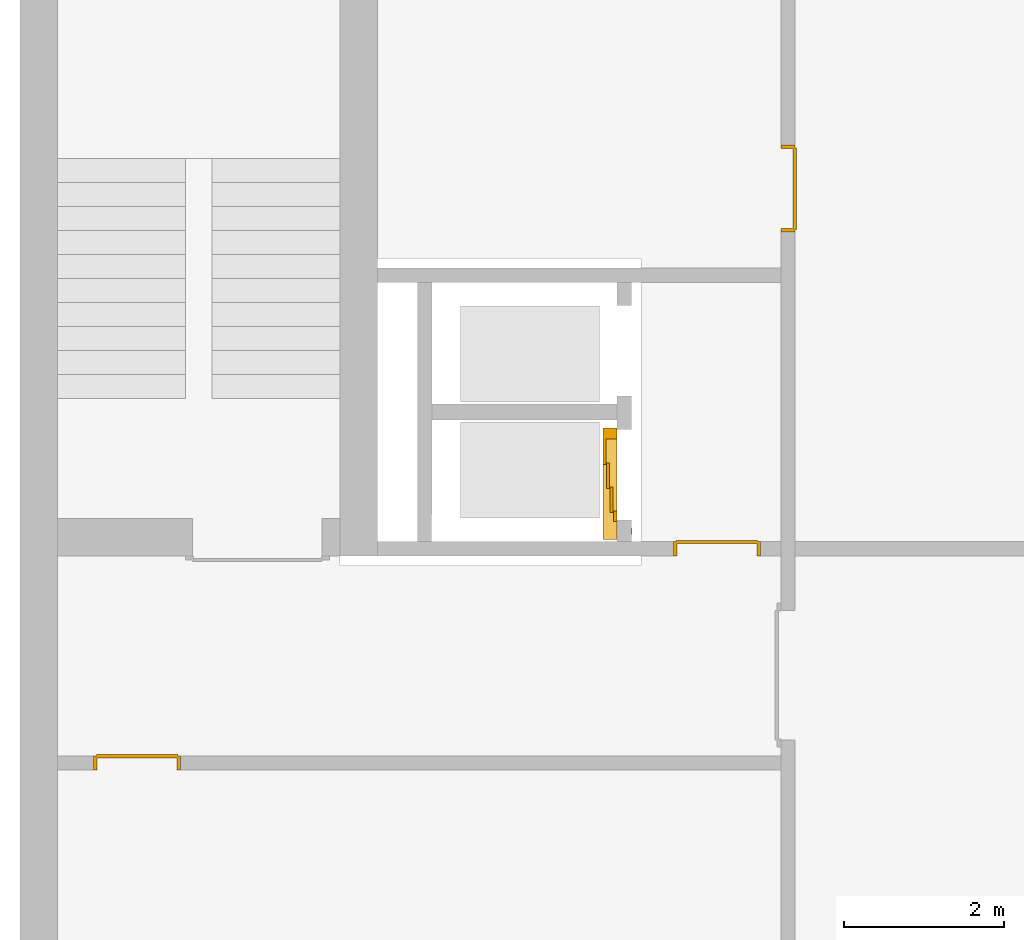
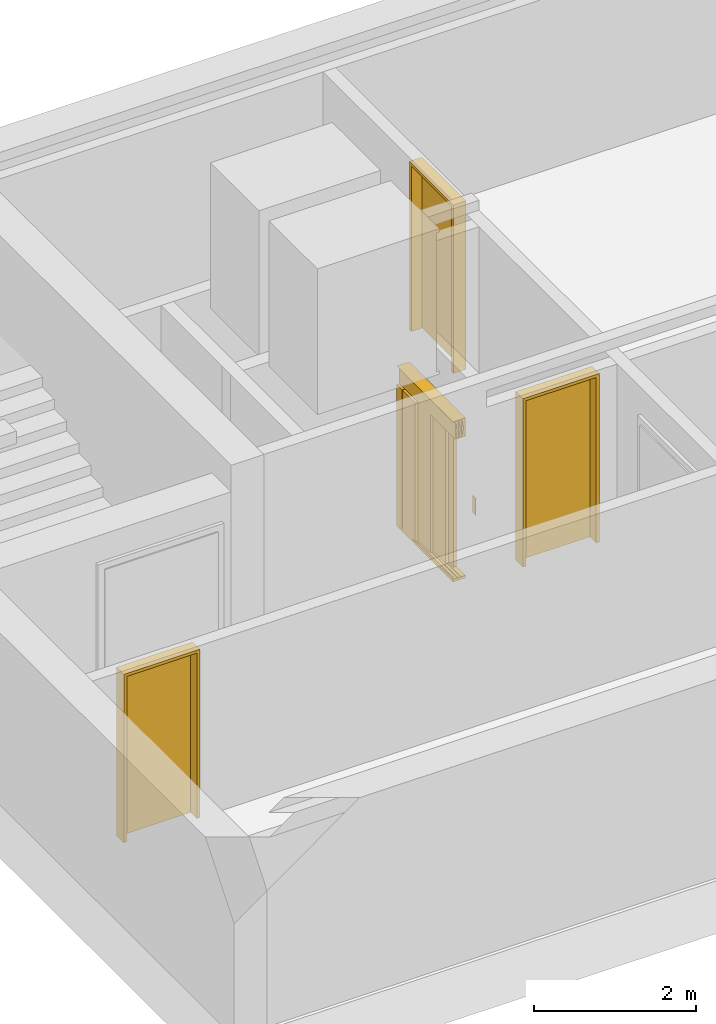
# One storey, part 4 of 5: 4 doors.
"""IFC4 building model written with IfcOpenShell, lengths in metres."""

from ifc_helpers import new_model, entity, si_unit, converted_unit, derived_unit, direction, frame, origin_with_axes, place, context, subcontext, project, spatial, polygons, source, transform, mapped, type_object, element, save


model = new_model("IFC4")

# Units and contexts
model_context = context("Model", 3, precision=1e-05, world=origin_with_axes(), true_north=direction((0.0, 1.0)))
body_context = subcontext(model_context, "Body", "Model", "MODEL_VIEW")
ifc_project = project(units=[si_unit("LENGTHUNIT", "METRE"), si_unit("AREAUNIT", "SQUARE_METRE"), si_unit("VOLUMEUNIT", "CUBIC_METRE"), converted_unit("PLANEANGLEUNIT", "DEGREE", entity("IfcPlaneAngleMeasure", 0.0174532925199433), si_unit("PLANEANGLEUNIT", "RADIAN"), dimensions=[0, 0, 0, 0, 0, 0, 0]), converted_unit("TIMEUNIT", "Year", entity("IfcTimeMeasure", 31557600.0), si_unit("TIMEUNIT", "SECOND"), dimensions=[0, 0, 1, 0, 0, 0, 0]), si_unit("MASSUNIT", "GRAM", prefix="KILO"), si_unit("THERMODYNAMICTEMPERATUREUNIT", "DEGREE_CELSIUS"), si_unit("LUMINOUSINTENSITYUNIT", "LUMEN"), si_unit("ENERGYUNIT", "JOULE", prefix="MEGA"), derived_unit("THERMALCONDUCTANCEUNIT", [(si_unit("POWERUNIT", "WATT"), 1), (si_unit("LENGTHUNIT", "METRE"), -1), (si_unit("THERMODYNAMICTEMPERATUREUNIT", "KELVIN"), -1)]), derived_unit("SPECIFICHEATCAPACITYUNIT", [(si_unit("ENERGYUNIT", "JOULE"), 1), (si_unit("MASSUNIT", "GRAM", prefix="KILO"), -1), (si_unit("THERMODYNAMICTEMPERATUREUNIT", "KELVIN"), -1)]), derived_unit("MASSDENSITYUNIT", [(si_unit("MASSUNIT", "GRAM", prefix="KILO"), 1), (si_unit("VOLUMEUNIT", "CUBIC_METRE"), -1)])], contexts=[model_context])

# Site, building, storey
site_placement = place(None, origin_with_axes())
site = spatial("IfcSite", under=ifc_project, at=site_placement, CompositionType="ELEMENT")
building_placement = place(None, origin_with_axes())
building = spatial("IfcBuilding", under=site, at=building_placement, CompositionType="ELEMENT")
storey_placement = place(None, frame((0.0, 0.0, -3.0), z_axis=(0.0, 0.0, 1.0), x_axis=(1.0, 0.0, 0.0)))
storey = spatial("IfcBuildingStorey", under=building, at=storey_placement, Name="UG", CompositionType="ELEMENT", Elevation=-3.0)

# Doors
door_type_1 = type_object("IfcDoorType", Name="27", OperationType="DOUBLE_DOOR_SLIDING", PredefinedType="DOOR")
shared_shape = source(origin_with_axes(), body_context, "Body", "Tessellation", [
    polygons([(-0.808333333333334, 0.135, 2.1), (-0.808333333333334, 0.135, 2.138), (0.585, 0.135, 2.138), (0.585, 0.135, 2.1), (-0.808333333333334, 0.0, 2.1), (-0.808333333333334, 0.0, 2.38), (-0.808333333333334, 0.18, 2.38), (-0.808333333333334, 0.18, 2.377), (-0.808333333333334, 0.003, 2.377), (-0.808333333333334, 0.003, 2.103), (-0.808333333333334, 0.132, 2.103), (-0.808333333333334, 0.132, 2.138), (0.585, 0.132, 2.138), (0.585, 0.132, 2.103), (0.585, 0.00299999999999992, 2.103), (0.585, 0.00299999999999992, 2.377), (0.585, 0.18, 2.377), (0.585, 0.18, 2.38), (0.585, 0.0, 2.38), (0.585, 0.0, 2.1)], [[[1, 2, 3, 4]], [[1, 5, 6, 7, 8, 9, 10, 11, 12, 2]], [[2, 12, 13, 3]], [[4, 3, 13, 14, 15, 16, 17, 18, 19, 20]], [[5, 1, 4, 20]], [[6, 5, 20, 19]], [[7, 6, 19, 18]], [[8, 7, 18, 17]], [[9, 8, 17, 16]], [[10, 9, 16, 15]], [[11, 10, 15, 14]], [[12, 11, 14, 13]]], closed=True),
    polygons([(-0.808333333333334, 0.05, 2.103), (-0.808333333333334, 0.055, 2.103), (0.585, 0.0549999999999999, 2.103), (0.585, 0.0499999999999999, 2.103), (-0.808333333333334, 0.05, 2.34), (-0.808333333333334, 0.055, 2.34), (0.585, 0.0549999999999999, 2.34), (0.585, 0.0499999999999999, 2.34)], [[[1, 2, 3, 4]], [[1, 5, 6, 2]], [[2, 6, 7, 3]], [[4, 3, 7, 8]], [[5, 1, 4, 8]], [[6, 5, 8, 7]]], closed=True),
    polygons([(-0.808333333333334, 0.05, 2.33), (-0.808333333333334, 0.04, 2.33), (0.585, 0.0399999999999999, 2.33), (0.585, 0.0499999999999999, 2.33), (-0.808333333333334, 0.05, 2.27), (-0.808333333333334, 0.04, 2.27), (0.585, 0.0399999999999999, 2.27), (0.585, 0.0499999999999999, 2.27)], [[[1, 2, 3, 4]], [[1, 5, 6, 2]], [[2, 6, 7, 3]], [[4, 3, 7, 8]], [[5, 1, 4, 8]], [[6, 5, 8, 7]]], closed=True),
    polygons([(-0.808333333333334, 0.05, 2.2), (-0.808333333333334, 0.04, 2.2), (0.585, 0.0399999999999999, 2.2), (0.585, 0.0499999999999999, 2.2), (-0.808333333333334, 0.05, 2.16), (-0.808333333333334, 0.04, 2.16), (0.585, 0.0399999999999999, 2.16), (0.585, 0.0499999999999999, 2.16)], [[[1, 2, 3, 4]], [[1, 5, 6, 2]], [[2, 6, 7, 3]], [[4, 3, 7, 8]], [[5, 1, 4, 8]], [[6, 5, 8, 7]]], closed=True),
    polygons([(-0.808333333333334, 0.05, 2.27), (-0.808333333333334, 0.03, 2.27), (0.585, 0.0299999999999999, 2.27), (0.585, 0.0499999999999999, 2.27), (-0.808333333333334, 0.05, 2.2), (-0.808333333333334, 0.03, 2.2), (0.585, 0.0299999999999999, 2.2), (0.585, 0.0499999999999999, 2.2)], [[[1, 2, 3, 4]], [[1, 5, 6, 2]], [[2, 6, 7, 3]], [[4, 3, 7, 8]], [[5, 1, 4, 8]], [[6, 5, 8, 7]]], closed=True),
    polygons([(-0.808333333333334, 0.095, 2.103), (-0.808333333333334, 0.1, 2.103), (0.585, 0.0999999999999999, 2.103), (0.585, 0.0949999999999999, 2.103), (-0.808333333333334, 0.095, 2.34), (-0.808333333333334, 0.1, 2.34), (0.585, 0.0999999999999999, 2.34), (0.585, 0.0949999999999999, 2.34)], [[[1, 2, 3, 4]], [[1, 5, 6, 2]], [[2, 6, 7, 3]], [[4, 3, 7, 8]], [[5, 1, 4, 8]], [[6, 5, 8, 7]]], closed=True),
    polygons([(-0.808333333333334, 0.095, 2.33), (-0.808333333333334, 0.085, 2.33), (0.585, 0.0849999999999999, 2.33), (0.585, 0.0949999999999999, 2.33), (-0.808333333333334, 0.095, 2.27), (-0.808333333333334, 0.085, 2.27), (0.585, 0.0849999999999999, 2.27), (0.585, 0.0949999999999999, 2.27)], [[[1, 2, 3, 4]], [[1, 5, 6, 2]], [[2, 6, 7, 3]], [[4, 3, 7, 8]], [[5, 1, 4, 8]], [[6, 5, 8, 7]]], closed=True),
    polygons([(-0.808333333333334, 0.095, 2.2), (-0.808333333333334, 0.085, 2.2), (0.585, 0.0849999999999999, 2.2), (0.585, 0.0949999999999999, 2.2), (-0.808333333333334, 0.095, 2.16), (-0.808333333333334, 0.085, 2.16), (0.585, 0.0849999999999999, 2.16), (0.585, 0.0949999999999999, 2.16)], [[[1, 2, 3, 4]], [[1, 5, 6, 2]], [[2, 6, 7, 3]], [[4, 3, 7, 8]], [[5, 1, 4, 8]], [[6, 5, 8, 7]]], closed=True),
    polygons([(-0.808333333333334, 0.095, 2.27), (-0.808333333333334, 0.075, 2.27), (0.585, 0.0749999999999999, 2.27), (0.585, 0.0949999999999999, 2.27), (-0.808333333333334, 0.095, 2.2), (-0.808333333333334, 0.075, 2.2), (0.585, 0.0749999999999999, 2.2), (0.585, 0.0949999999999999, 2.2)], [[[1, 2, 3, 4]], [[1, 5, 6, 2]], [[2, 6, 7, 3]], [[4, 3, 7, 8]], [[5, 1, 4, 8]], [[6, 5, 8, 7]]], closed=True),
    polygons([(-0.808333333333334, 0.14, 2.103), (-0.808333333333334, 0.145, 2.103), (0.585, 0.145, 2.103), (0.585, 0.14, 2.103), (-0.808333333333334, 0.14, 2.34), (-0.808333333333334, 0.145, 2.34), (0.585, 0.145, 2.34), (0.585, 0.14, 2.34)], [[[1, 2, 3, 4]], [[1, 5, 6, 2]], [[2, 6, 7, 3]], [[4, 3, 7, 8]], [[5, 1, 4, 8]], [[6, 5, 8, 7]]], closed=True),
    polygons([(-0.808333333333334, 0.14, 2.33), (-0.808333333333334, 0.13, 2.33), (0.585, 0.13, 2.33), (0.585, 0.14, 2.33), (-0.808333333333334, 0.14, 2.27), (-0.808333333333334, 0.13, 2.27), (0.585, 0.13, 2.27), (0.585, 0.14, 2.27)], [[[1, 2, 3, 4]], [[1, 5, 6, 2]], [[2, 6, 7, 3]], [[4, 3, 7, 8]], [[5, 1, 4, 8]], [[6, 5, 8, 7]]], closed=True),
    polygons([(-0.808333333333334, 0.14, 2.2), (-0.808333333333334, 0.13, 2.2), (0.585, 0.13, 2.2), (0.585, 0.14, 2.2), (-0.808333333333334, 0.14, 2.16), (-0.808333333333334, 0.13, 2.16), (0.585, 0.13, 2.16), (0.585, 0.14, 2.16)], [[[1, 2, 3, 4]], [[1, 5, 6, 2]], [[2, 6, 7, 3]], [[4, 3, 7, 8]], [[5, 1, 4, 8]], [[6, 5, 8, 7]]], closed=True),
    polygons([(-0.808333333333334, 0.14, 2.27), (-0.808333333333334, 0.12, 2.27), (0.585, 0.12, 2.27), (0.585, 0.14, 2.27), (-0.808333333333334, 0.14, 2.2), (-0.808333333333334, 0.12, 2.2), (0.585, 0.12, 2.2), (0.585, 0.14, 2.2)], [[[1, 2, 3, 4]], [[1, 5, 6, 2]], [[2, 6, 7, 3]], [[4, 3, 7, 8]], [[5, 1, 4, 8]], [[6, 5, 8, 7]]], closed=True),
    polygons([(-0.808333333333334, 0.0, 0.0), (-0.808333333333334, 0.0, -0.04), (0.585, 0.0, -0.04), (0.585, 0.0, 0.0), (-0.808333333333334, 0.065, 0.0), (-0.808333333333334, 0.065, -0.01), (-0.808333333333334, 0.075, -0.01), (-0.808333333333334, 0.075, 0.0), (-0.808333333333334, 0.11, 0.0), (-0.808333333333334, 0.11, -0.01), (-0.808333333333334, 0.12, -0.01), (-0.808333333333334, 0.12, 0.0), (-0.808333333333334, 0.155, 0.0), (-0.808333333333334, 0.155, -0.01), (-0.808333333333334, 0.165, -0.01), (-0.808333333333334, 0.165, 0.0), (-0.808333333333334, 0.18, 0.0), (-0.808333333333334, 0.18, -0.04), (0.585, 0.18, -0.04), (0.585, 0.18, 0.0), (0.585, 0.165, 0.0), (0.585, 0.165, -0.01), (0.585, 0.155, -0.01), (0.585, 0.155, 0.0), (0.585, 0.12, 0.0), (0.585, 0.12, -0.01), (0.585, 0.11, -0.01), (0.585, 0.11, 0.0), (0.585, 0.0749999999999999, 0.0), (0.585, 0.0749999999999999, -0.01), (0.585, 0.0649999999999999, -0.01), (0.585, 0.0649999999999999, 0.0)], [[[1, 2, 3, 4]], [[1, 5, 6, 7, 8, 9, 10, 11, 12, 13, 14, 15, 16, 17, 18, 2]], [[2, 18, 19, 3]], [[4, 3, 19, 20, 21, 22, 23, 24, 25, 26, 27, 28, 29, 30, 31, 32]], [[5, 1, 4, 32]], [[6, 5, 32, 31]], [[7, 6, 31, 30]], [[8, 7, 30, 29]], [[9, 8, 29, 28]], [[10, 9, 28, 27]], [[11, 10, 27, 26]], [[12, 11, 26, 25]], [[13, 12, 25, 24]], [[14, 13, 24, 23]], [[15, 14, 23, 22]], [[16, 15, 22, 21]], [[17, 16, 21, 20]], [[18, 17, 20, 19]]], closed=True),
    polygons([(-0.45, 0.0, 0.0), (-0.45, 0.045, 0.0), (-0.45, 0.0449999999999999, 2.1), (-0.45, 0.0, 2.1), (-0.585, 0.0, 0.0), (-0.585, 0.045, 0.0), (-0.585, 0.0449999999999999, 2.1), (-0.585, 0.0, 2.1)], [[[1, 2, 3, 4]], [[1, 5, 6, 2]], [[2, 6, 7, 3]], [[4, 3, 7, 8]], [[5, 1, 4, 8]], [[6, 5, 8, 7]]], closed=True),
    polygons([(0.585, 0.0, 0.0), (0.585, 0.18, 0.0), (0.585, 0.18, 2.1), (0.585, 0.0, 2.1), (0.45, 0.0, 0.0), (0.45, 0.18, 0.0), (0.45, 0.18, 2.1), (0.45, 0.0, 2.1)], [[[1, 2, 3, 4]], [[1, 5, 6, 2]], [[2, 6, 7, 3]], [[4, 3, 7, 8]], [[5, 1, 4, 8]], [[6, 5, 8, 7]]], closed=True),
    polygons([(-0.745, -0.18, 0.8), (-0.665, -0.18, 0.8), (-0.665, -0.183, 0.8), (-0.745, -0.183, 0.8), (-0.745, -0.18, 1.06), (-0.665, -0.18, 1.06), (-0.735, -0.18, 1.03), (-0.735, -0.18, 0.94), (-0.675, -0.18, 0.94), (-0.675, -0.18, 1.03), (-0.715, -0.18, 0.84), (-0.695, -0.18, 0.84), (-0.695, -0.18, 0.86), (-0.715, -0.18, 0.86), (-0.715, -0.18, 0.88), (-0.695, -0.18, 0.88), (-0.695, -0.18, 0.9), (-0.715, -0.18, 0.9), (-0.665, -0.183, 1.06), (-0.745, -0.183, 1.06), (-0.735, -0.183, 1.03), (-0.675, -0.183, 1.03), (-0.675, -0.183, 0.94), (-0.735, -0.183, 0.94), (-0.715, -0.183, 0.84), (-0.715, -0.183, 0.86), (-0.695, -0.183, 0.86), (-0.695, -0.183, 0.84), (-0.715, -0.183, 0.88), (-0.715, -0.183, 0.9), (-0.695, -0.183, 0.9), (-0.695, -0.183, 0.88)], [[[1, 2, 3, 4]], [[1, 5, 6, 2], [7, 8, 9, 10], [11, 12, 13, 14], [15, 16, 17, 18]], [[2, 6, 19, 3]], [[4, 3, 19, 20], [21, 22, 23, 24], [25, 26, 27, 28], [29, 30, 31, 32]], [[5, 1, 4, 20]], [[6, 5, 20, 19]], [[8, 7, 21, 24]], [[9, 8, 24, 23]], [[10, 9, 23, 22]], [[7, 10, 22, 21]], [[12, 11, 25, 28]], [[13, 12, 28, 27]], [[14, 13, 27, 26]], [[11, 14, 26, 25]], [[16, 15, 29, 32]], [[17, 16, 32, 31]], [[18, 17, 31, 30]], [[15, 18, 30, 29]]], closed=True),
    polygons([(-0.735, -0.18, 0.94), (-0.675, -0.18, 0.94), (-0.675, -0.1825, 0.94), (-0.735, -0.1825, 0.94), (-0.735, -0.18, 1.03), (-0.675, -0.18, 1.03), (-0.675, -0.1825, 1.03), (-0.735, -0.1825, 1.03)], [[[1, 2, 3, 4]], [[1, 5, 6, 2]], [[2, 6, 7, 3]], [[4, 3, 7, 8]], [[5, 1, 4, 8]], [[6, 5, 8, 7]]], closed=True),
    polygons([(-0.721, -0.183, 1.005), (-0.715, -0.183, 1.021), (-0.709, -0.183, 1.005)], [[[1, 2, 3]]], closed=False),
    polygons([(-0.695, -0.183, 1.005), (-0.701, -0.183, 1.021), (-0.689, -0.183, 1.021)], [[[1, 2, 3]]], closed=False),
    polygons([(-0.707727272727273, -0.1835, 0.982), (-0.707727272727273, -0.1835, 0.971636363636364), (-0.709090909090909, -0.1835, 0.970272727272727), (-0.710454545454546, -0.1835, 0.971636363636364), (-0.710454545454546, -0.1835, 0.982), (-0.709090909090909, -0.1835, 0.983363636363636)], [[[1, 2, 3, 4, 5, 6]]], closed=False),
    polygons([(-0.707727272727273, -0.1835, 0.968363636363636), (-0.707727272727273, -0.1835, 0.958), (-0.709090909090909, -0.1835, 0.956636363636364), (-0.710454545454546, -0.1835, 0.958), (-0.710454545454546, -0.1835, 0.968363636363636), (-0.709090909090909, -0.1835, 0.969727272727273)], [[[1, 2, 3, 4, 5, 6]]], closed=False),
    polygons([(-0.688909090909091, -0.1835, 0.982272727272727), (-0.699272727272727, -0.1835, 0.982272727272727), (-0.700636363636364, -0.1835, 0.983636363636364), (-0.699272727272727, -0.1835, 0.985), (-0.688909090909091, -0.1835, 0.985), (-0.687545454545455, -0.1835, 0.983636363636364)], [[[1, 2, 3, 4, 5, 6]]], closed=False),
    polygons([(-0.685909090909091, -0.1835, 0.982), (-0.685909090909091, -0.1835, 0.971636363636364), (-0.687272727272727, -0.1835, 0.970272727272727), (-0.688636363636364, -0.1835, 0.971636363636364), (-0.688636363636364, -0.1835, 0.982), (-0.687272727272727, -0.1835, 0.983363636363636)], [[[1, 2, 3, 4, 5, 6]]], closed=False),
    polygons([(-0.688909090909091, -0.1835, 0.968636363636364), (-0.699272727272727, -0.1835, 0.968636363636364), (-0.700636363636364, -0.1835, 0.97), (-0.699272727272727, -0.1835, 0.971363636363636), (-0.688909090909091, -0.1835, 0.971363636363636), (-0.687545454545455, -0.1835, 0.97)], [[[1, 2, 3, 4, 5, 6]]], closed=False),
    polygons([(-0.699545454545455, -0.1835, 0.968363636363636), (-0.699545454545455, -0.1835, 0.958), (-0.700909090909091, -0.1835, 0.956636363636364), (-0.702272727272727, -0.1835, 0.958), (-0.702272727272727, -0.1835, 0.968363636363636), (-0.700909090909091, -0.1835, 0.969727272727273)], [[[1, 2, 3, 4, 5, 6]]], closed=False),
    polygons([(-0.688909090909091, -0.1835, 0.955), (-0.699272727272727, -0.1835, 0.955), (-0.700636363636364, -0.1835, 0.956363636363636), (-0.699272727272727, -0.1835, 0.957727272727273), (-0.688909090909091, -0.1835, 0.957727272727273), (-0.687545454545455, -0.1835, 0.956363636363636)], [[[1, 2, 3, 4, 5, 6]]], closed=False),
    polygons([(-0.695, -0.18, 0.84), (-0.715, -0.18, 0.84), (-0.715, -0.18, 0.86), (-0.695, -0.18, 0.86), (-0.694999999905229, -0.1815, 0.839999999610484), (-0.715000000389516, -0.1815, 0.839999999610484), (-0.715000000389516, -0.1815, 0.860000000094772), (-0.694999999905229, -0.1815, 0.860000000094772), (-0.696400000320971, -0.182900000415742, 0.841400000026226), (-0.713599999973774, -0.182900000415742, 0.841400000026226), (-0.713599999973774, -0.182900000415742, 0.858599999679029), (-0.696400000320971, -0.182900000415742, 0.858599999679029)], [[[1, 2, 3, 4]], [[2, 1, 5, 6]], [[3, 2, 6, 7]], [[4, 3, 7, 8]], [[1, 4, 8, 5]], [[6, 5, 9, 10]], [[7, 6, 10, 11]], [[8, 7, 11, 12]], [[5, 8, 12, 9]], [[11, 10, 9, 12]]], closed=True),
    polygons([(-0.7, -0.183, 0.855), (-0.705, -0.183, 0.844), (-0.71, -0.183, 0.855)], [[[1, 2, 3]]], closed=False),
    polygons([(-0.695, -0.18, 0.88), (-0.715, -0.18, 0.88), (-0.715, -0.18, 0.9), (-0.695, -0.18, 0.9), (-0.694999999905229, -0.1815, 0.879999999610484), (-0.715000000389516, -0.1815, 0.879999999610484), (-0.715000000389516, -0.1815, 0.900000000094772), (-0.694999999905229, -0.1815, 0.900000000094772), (-0.696400000320971, -0.182900000415742, 0.881400000026226), (-0.713599999973774, -0.182900000415742, 0.881400000026226), (-0.713599999973774, -0.182900000415742, 0.898599999679029), (-0.696400000320971, -0.182900000415742, 0.898599999679029)], [[[1, 2, 3, 4]], [[2, 1, 5, 6]], [[3, 2, 6, 7]], [[4, 3, 7, 8]], [[1, 4, 8, 5]], [[6, 5, 9, 10]], [[7, 6, 10, 11]], [[8, 7, 11, 12]], [[5, 8, 12, 9]], [[11, 10, 9, 12]]], closed=True),
    polygons([(-0.7, -0.183, 0.885), (-0.71, -0.183, 0.885), (-0.705, -0.183, 0.896)], [[[1, 2, 3]]], closed=False),
    polygons([(0.126666666666667, 0.14, 0.003), (0.126666666666667, 0.18, 0.003), (0.445, 0.18, 0.003), (0.445, 0.14, 0.003), (0.126666666666667, 0.14, 2.1), (0.126666666666667, 0.18, 2.1), (0.445, 0.18, 2.1), (0.445, 0.14, 2.1)], [[[1, 2, 3, 4]], [[5, 6, 2, 1]], [[2, 6, 7, 3]], [[4, 3, 7, 8]], [[1, 4, 8, 5]], [[8, 7, 6, 5]]], closed=True),
    polygons([(-0.171666666666667, 0.095, 0.003), (-0.171666666666667, 0.135, 0.003), (0.146666666666667, 0.135, 0.003), (0.146666666666667, 0.095, 0.003), (-0.171666666666667, 0.095, 2.1), (-0.171666666666667, 0.135, 2.1), (0.146666666666667, 0.135, 2.1), (0.146666666666667, 0.095, 2.1)], [[[1, 2, 3, 4]], [[5, 6, 2, 1]], [[2, 6, 7, 3]], [[4, 3, 7, 8]], [[1, 4, 8, 5]], [[8, 7, 6, 5]]], closed=True),
    polygons([(-0.47, 0.05, 0.003), (-0.47, 0.09, 0.003), (-0.151666666666667, 0.09, 0.003), (-0.151666666666667, 0.05, 0.003), (-0.47, 0.05, 2.1), (-0.47, 0.09, 2.1), (-0.151666666666667, 0.09, 2.1), (-0.151666666666667, 0.05, 2.1)], [[[1, 2, 3, 4]], [[5, 6, 2, 1]], [[2, 6, 7, 3]], [[4, 3, 7, 8]], [[1, 4, 8, 5]], [[8, 7, 6, 5]]], closed=True),
])
door_1_placement = place(None, frame((31.638, 7.61999994546756, -3.0), z_axis=(0.0, 0.0, 1.0), x_axis=(0.0, 1.0, 0.0)))
element("IfcDoor", 1, at=door_1_placement, inside=storey, type_object=door_type_1, OverallHeight=2.25, OverallWidth=1.13, context=body_context, shape_type="MappedRepresentation", body=[
    mapped(shared_shape, transform((0.450000000000001, 0.18, 0.0))),
])
door_type_2 = type_object("IfcDoorType", Name="27", OperationType="SINGLE_SWING_LEFT", PredefinedType="DOOR")
door_2_placement = place(None, frame((33.505, 12.1499999454676, -3.0), z_axis=(0.0, 0.0, 1.0), x_axis=(0.0, -1.0, 0.0)))
element("IfcDoor", 2, at=door_2_placement, inside=storey, type_object=door_type_2, OverallHeight=2.545, OverallWidth=1.09, context=body_context, shape_type="Tessellation", body=[
    polygons([(-0.0449999999999999, 0.0, 0.0), (-0.0449999999999999, 0.0, 2.545), (-0.0449999999999999, 0.155000000000001, 2.545), (-0.0449999999999999, 0.155000000000001, 0.0), (0.0, 0.0, 0.0), (0.0, 0.0, 2.5), (0.444900000000001, 0.0, 2.5), (0.4999, 0.0, 2.5), (1.0, 0.0, 2.5), (1.0, 0.0, 0.0), (1.045, 0.0, 0.0), (1.045, 0.0, 2.545), (1.045, 0.155000000000001, 2.545), (1.045, 0.155000000000001, 0.0), (1.0, 0.155000000000001, 0.0), (1.0, 0.155000000000001, 2.5), (0.4999, 0.155000000000001, 2.5), (0.444900000000001, 0.155000000000001, 2.5), (0.0, 0.155000000000001, 2.5), (0.0, 0.155000000000001, 0.0)], [[[1, 2, 3, 4]], [[1, 5, 6, 7, 8, 9, 10, 11, 12, 2]], [[2, 12, 13, 3]], [[4, 3, 13, 14, 15, 16, 17, 18, 19, 20]], [[5, 1, 4, 20]], [[6, 5, 20, 19]], [[7, 6, 19, 18]], [[8, 7, 18, 17]], [[9, 8, 17, 16]], [[10, 9, 16, 15]], [[11, 10, 15, 14]], [[12, 11, 14, 13]]], closed=True),
    polygons([(-0.0449999999999999, 0.155000000000001, 0.0), (-0.0449999999999999, 0.155000000000001, 2.545), (-0.0449999999999999, 0.18, 2.545), (-0.0449999999999999, 0.18, 0.0), (-0.00999999999999979, 0.155000000000001, 0.0), (-0.00999999999999979, 0.155000000000001, 2.51), (0.4549, 0.155000000000001, 2.51), (0.4899, 0.155000000000001, 2.51), (1.01, 0.155000000000001, 2.51), (1.01, 0.155000000000001, 0.0), (1.045, 0.155000000000001, 0.0), (1.045, 0.155000000000001, 2.545), (1.045, 0.18, 2.545), (1.045, 0.18, 0.0), (1.01, 0.18, 0.0), (1.01, 0.18, 2.51), (0.4899, 0.18, 2.51), (0.4549, 0.18, 2.51), (-0.00999999999999979, 0.18, 2.51), (-0.00999999999999979, 0.18, 0.0)], [[[1, 2, 3, 4]], [[1, 5, 6, 7, 8, 9, 10, 11, 12, 2]], [[2, 12, 13, 3]], [[4, 3, 13, 14, 15, 16, 17, 18, 19, 20]], [[5, 1, 4, 20]], [[6, 5, 20, 19]], [[7, 6, 19, 18]], [[8, 7, 18, 17]], [[9, 8, 17, 16]], [[10, 9, 16, 15]], [[11, 10, 15, 14]], [[12, 11, 14, 13]]], closed=True),
    polygons([(-0.00999999999999979, 0.195, 0.0), (-0.00999999999999979, 0.195, 2.51), (1.01, 0.195, 2.51), (1.01, 0.195, 0.0), (-0.00999999999999979, 0.155000000000001, 0.0), (-0.00999999999999979, 0.155000000000001, 2.51), (1.01, 0.155000000000001, 2.51), (1.01, 0.155000000000001, 0.0)], [[[1, 2, 3, 4]], [[1, 5, 6, 2]], [[2, 6, 7, 3]], [[3, 7, 8, 4]], [[4, 8, 5, 1]], [[8, 7, 6, 5]]], closed=True),
])
door_3_placement = place(None, frame((24.953, 4.55499994546755, -3.0), z_axis=(0.0, 0.0, 1.0), x_axis=(1.0, 0.0, 0.0)))
element("IfcDoor", 3, at=door_3_placement, inside=storey, type_object=door_type_2, OverallHeight=2.545, OverallWidth=1.09, context=body_context, shape_type="Tessellation", body=[
    polygons([(-0.0449999999999982, -0.179999999999999, 0.0), (-0.0449999999999982, -0.179999999999999, 2.545), (-0.0449999999999982, -0.0249999999999995, 2.545), (-0.0449999999999982, -0.0249999999999986, 0.0), (0.0, -0.179999999999999, 0.0), (0.0, -0.179999999999999, 2.5), (0.444900000000001, -0.179999999999999, 2.5), (0.4999, -0.179999999999999, 2.5), (1.0, -0.18, 2.5), (1.0, -0.179999999999999, 0.0), (1.045, -0.179999999999999, 0.0), (1.045, -0.18, 2.545), (1.045, -0.0249999999999995, 2.545), (1.045, -0.0249999999999995, 0.0), (1.0, -0.0249999999999995, 0.0), (1.0, -0.0249999999999995, 2.5), (0.4999, -0.0249999999999995, 2.5), (0.444900000000001, -0.0249999999999995, 2.5), (0.0, -0.0249999999999995, 2.5), (0.0, -0.0249999999999986, 0.0)], [[[1, 2, 3, 4]], [[1, 5, 6, 7, 8, 9, 10, 11, 12, 2]], [[2, 12, 13, 3]], [[4, 3, 13, 14, 15, 16, 17, 18, 19, 20]], [[5, 1, 4, 20]], [[6, 5, 20, 19]], [[7, 6, 19, 18]], [[8, 7, 18, 17]], [[9, 8, 17, 16]], [[10, 9, 16, 15]], [[11, 10, 15, 14]], [[12, 11, 14, 13]]], closed=True),
    polygons([(-0.0449999999999982, -0.0249999999999986, 0.0), (-0.0449999999999982, -0.0249999999999995, 2.545), (-0.0449999999999982, 0.0, 2.545), (-0.0449999999999982, 0.0, 0.0), (-0.0100000000000016, -0.0249999999999986, 0.0), (-0.0100000000000016, -0.0249999999999995, 2.51), (0.454899999999999, -0.0249999999999995, 2.51), (0.489899999999999, -0.0249999999999995, 2.51), (1.01, -0.0249999999999995, 2.51), (1.01, -0.0249999999999995, 0.0), (1.045, -0.0249999999999995, 0.0), (1.045, -0.0249999999999995, 2.545), (1.045, 0.0, 2.545), (1.045, 0.0, 0.0), (1.01, 0.0, 0.0), (1.01, 0.0, 2.51), (0.489899999999999, 0.0, 2.51), (0.454899999999999, 0.0, 2.51), (-0.0100000000000016, 0.0, 2.51), (-0.0100000000000016, 0.0, 0.0)], [[[1, 2, 3, 4]], [[1, 5, 6, 7, 8, 9, 10, 11, 12, 2]], [[2, 12, 13, 3]], [[4, 3, 13, 14, 15, 16, 17, 18, 19, 20]], [[5, 1, 4, 20]], [[6, 5, 20, 19]], [[7, 6, 19, 18]], [[8, 7, 18, 17]], [[9, 8, 17, 16]], [[10, 9, 16, 15]], [[11, 10, 15, 14]], [[12, 11, 14, 13]]], closed=True),
    polygons([(-0.0100000000000016, 0.0150000000000015, 0.0), (-0.0100000000000016, 0.0150000000000006, 2.51), (1.01, 0.0150000000000006, 2.51), (1.01, 0.0150000000000006, 0.0), (-0.0100000000000016, -0.0249999999999986, 0.0), (-0.0100000000000016, -0.0249999999999995, 2.51), (1.01, -0.0249999999999995, 2.51), (1.01, -0.0249999999999995, 0.0)], [[[1, 2, 3, 4]], [[1, 5, 6, 2]], [[2, 6, 7, 3]], [[3, 7, 8, 4]], [[4, 8, 5, 1]], [[8, 7, 6, 5]]], closed=True),
])
door_type_3 = type_object("IfcDoorType", Name="27", OperationType="SINGLE_SWING_RIGHT", PredefinedType="DOOR")
door_4_placement = place(None, frame((32.205, 7.05499994546755, -3.0), z_axis=(0.0, 0.0, 1.0), x_axis=(1.0, 0.0, 0.0)))
element("IfcDoor", 4, at=door_4_placement, inside=storey, type_object=door_type_3, OverallHeight=2.545, OverallWidth=1.09, context=body_context, shape_type="Tessellation", body=[
    polygons([(1.045, 0.0, 0.0), (1.045, 0.154999999999999, 0.0), (1.045, 0.155, 2.545), (1.045, 0.0, 2.545), (1.0, 0.0, 0.0), (1.0, 0.154999999999999, 0.0), (1.0, 0.155, 2.5), (0.555100000000003, 0.155, 2.5), (0.500100000000003, 0.155, 2.5), (0.0, 0.155, 2.5), (0.0, 0.154999999999999, 0.0), (-0.0450000000000017, 0.154999999999999, 0.0), (-0.0450000000000017, 0.155, 2.545), (-0.0450000000000017, 0.0, 2.545), (-0.0450000000000017, 0.0, 0.0), (0.0, 0.0, 0.0), (0.0, 0.0, 2.5), (0.500100000000003, 0.0, 2.5), (0.555100000000003, 0.0, 2.5), (1.0, 0.0, 2.5)], [[[1, 2, 3, 4]], [[5, 6, 2, 1]], [[2, 6, 7, 8, 9, 10, 11, 12, 13, 3]], [[4, 3, 13, 14]], [[1, 4, 14, 15, 16, 17, 18, 19, 20, 5]], [[20, 7, 6, 5]], [[19, 8, 7, 20]], [[18, 9, 8, 19]], [[17, 10, 9, 18]], [[16, 11, 10, 17]], [[15, 12, 11, 16]], [[14, 13, 12, 15]]], closed=True),
    polygons([(1.045, 0.154999999999999, 0.0), (1.045, 0.18, 0.0), (1.045, 0.18, 2.545), (1.045, 0.155, 2.545), (1.01, 0.154999999999999, 0.0), (1.01, 0.18, 0.0), (1.01, 0.18, 2.51), (0.545099999999998, 0.18, 2.51), (0.510100000000001, 0.18, 2.51), (-0.00999999999999801, 0.18, 2.51), (-0.00999999999999801, 0.18, 0.0), (-0.0450000000000017, 0.18, 0.0), (-0.0450000000000017, 0.18, 2.545), (-0.0450000000000017, 0.155, 2.545), (-0.0450000000000017, 0.154999999999999, 0.0), (-0.00999999999999801, 0.154999999999999, 0.0), (-0.00999999999999801, 0.155, 2.51), (0.510100000000001, 0.155, 2.51), (0.545099999999998, 0.155, 2.51), (1.01, 0.155, 2.51)], [[[1, 2, 3, 4]], [[5, 6, 2, 1]], [[2, 6, 7, 8, 9, 10, 11, 12, 13, 3]], [[4, 3, 13, 14]], [[1, 4, 14, 15, 16, 17, 18, 19, 20, 5]], [[20, 7, 6, 5]], [[19, 8, 7, 20]], [[18, 9, 8, 19]], [[17, 10, 9, 18]], [[16, 11, 10, 17]], [[15, 12, 11, 16]], [[14, 13, 12, 15]]], closed=True),
    polygons([(1.01, 0.194999999999999, 0.0), (-0.00999999999999801, 0.194999999999999, 0.0), (-0.00999999999999801, 0.195, 2.51), (1.01, 0.195, 2.51), (1.01, 0.154999999999999, 0.0), (-0.00999999999999801, 0.154999999999999, 0.0), (-0.00999999999999801, 0.155, 2.51), (1.01, 0.155, 2.51)], [[[1, 2, 3, 4]], [[2, 1, 5, 6]], [[3, 2, 6, 7]], [[4, 3, 7, 8]], [[1, 4, 8, 5]], [[6, 5, 8, 7]]], closed=True),
])

save(model, "model.ifc")
